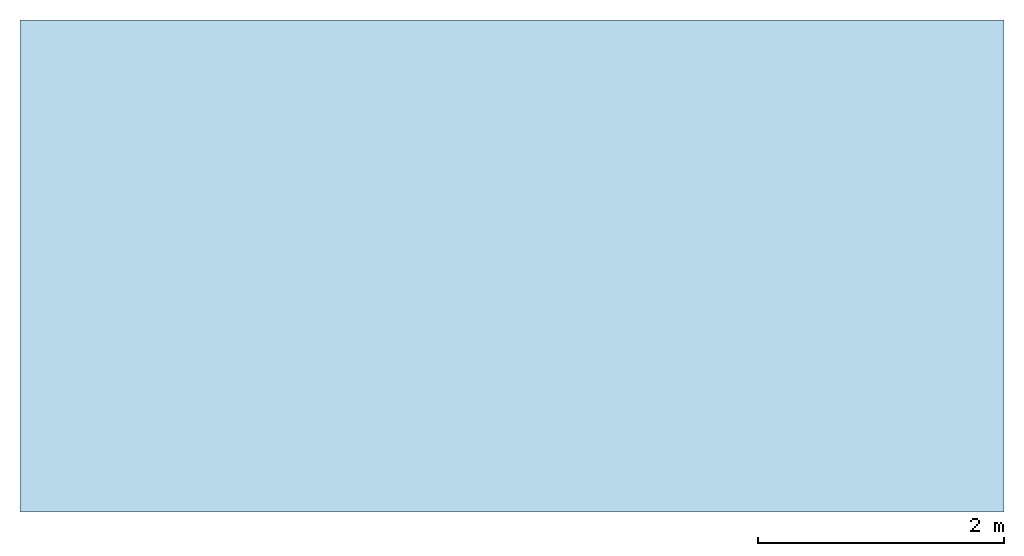
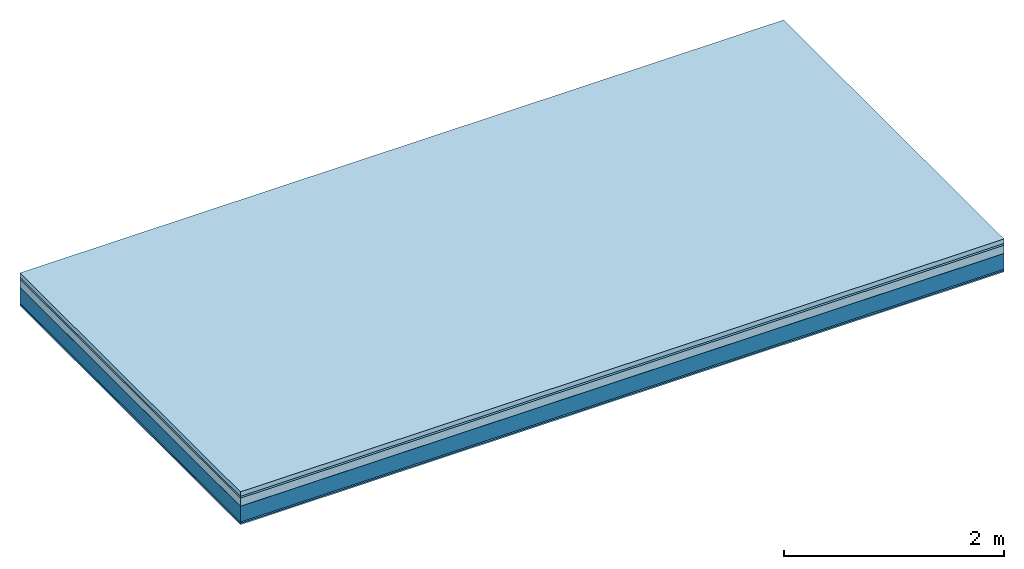
# One storey: 6 plates, 1 member, 1 element without a shape of its own.
"""IFC4 building model written with IfcOpenShell, lengths in metres."""

import ifcopenshell
import ifcopenshell.guid

model = None  # the IFC model being written
_history = None  # IfcOwnerHistory: only IFC2X3 demands one
_inside = {}  # id of a spatial element -> (the spatial element, [elements in it])
_under = {}  # id of a project, library or spatial element -> (it, [spatial elements below it])
_declared = {}  # id of a project -> (the project, [libraries it declares])
_typed = {}  # id of a type object -> (the type object, [elements of that type])
_made_of = {}  # id of a material, layer set ... -> (it, [elements and type objects made of it])


def new_model(schema):
    """Start an empty IFC model of exactly this schema.

    Asked for "IFC4X3", IfcOpenShell would pick the latest addendum, in which some entities
    have other attributes; the version numbers below select the first issue.
    IFC2X3 requires an IfcOwnerHistory on every rooted entity: one is made here for all.
    """
    global model, _history
    if schema == "IFC4X3":
        model = ifcopenshell.file(schema_version=(4, 3, 0, 0))
    else:
        model = ifcopenshell.file(schema=schema)
    _inside.clear()
    _under.clear()
    _declared.clear()
    _typed.clear()
    _made_of.clear()
    _history = None
    if model.schema == "IFC2X3":
        org = make("IfcOrganization", Name="unknown")
        user = make(
            "IfcPersonAndOrganization",
            ThePerson=make("IfcPerson", FamilyName="unknown"),
            TheOrganization=org,
        )
        app = make(
            "IfcApplication",
            ApplicationDeveloper=org,
            Version="unknown",
            ApplicationFullName="unknown",
            ApplicationIdentifier="unknown",
        )
        _history = make(
            "IfcOwnerHistory",
            OwningUser=user,
            OwningApplication=app,
            ChangeAction="ADDED",
            CreationDate=0,
        )
    return model


def make(cls, **values):
    """One entity of the class cls with the attributes given. An attribute that is None is left unset."""
    return model.create_entity(
        cls, **{name: value for name, value in values.items() if value is not None}
    )


def rooted(cls, **values):
    """An entity with a GlobalId (a new one), such as an element, a storey or a relation."""
    return make(cls, GlobalId=ifcopenshell.guid.new(), OwnerHistory=_history, **values)


def si_unit(unit_type, name, prefix=None):
    """IfcSIUnit, for example si_unit("LENGTHUNIT", "METRE", prefix="MILLI")."""
    return make("IfcSIUnit", UnitType=unit_type, Prefix=prefix, Name=name)


def derived_unit(unit_type, elements):
    """IfcDerivedUnit: a product of units, each with its exponent."""
    return make(
        "IfcDerivedUnit",
        Elements=[
            make("IfcDerivedUnitElement", Unit=unit, Exponent=power)
            for unit, power in elements
        ],
        UnitType=unit_type,
    )


def assignment(units):
    """IfcUnitAssignment: the units of a project."""
    return None if units is None else make("IfcUnitAssignment", Units=units)


def point(xyz):
    """IfcCartesianPoint."""
    return None if xyz is None else make("IfcCartesianPoint", Coordinates=xyz)


def direction(xyz):
    """IfcDirection."""
    return None if xyz is None else make("IfcDirection", DirectionRatios=xyz)


def frame(location, z_axis=None, x_axis=None):
    """IfcAxis2Placement3D, a coordinate frame: its origin and axes. An axis left out is left unset."""
    return make(
        "IfcAxis2Placement3D",
        Location=point(location),
        Axis=direction(z_axis),
        RefDirection=direction(x_axis),
    )


def frame_2d(location, x_axis=None):
    """IfcAxis2Placement2D, a coordinate frame in the plane: its origin and x axis."""
    return make(
        "IfcAxis2Placement2D", Location=point(location), RefDirection=direction(x_axis)
    )


def origin():
    """The frame at (0, 0, 0) with its axes left unset."""
    return frame((0.0, 0.0, 0.0))


def origin_with_axes():
    """The frame at (0, 0, 0) with the z axis (0, 0, 1) and the x axis (1, 0, 0) written out."""
    return frame((0.0, 0.0, 0.0), z_axis=(0.0, 0.0, 1.0), x_axis=(1.0, 0.0, 0.0))


def place(relative_to, where):
    """IfcLocalPlacement: puts the frame where relative to a parent placement (None: the world)."""
    return make(
        "IfcLocalPlacement", PlacementRelTo=relative_to, RelativePlacement=where
    )


def context(
    kind, dimensions, precision=None, world=None, true_north=None, identifier=None
):
    """IfcGeometricRepresentationContext, for example the 3D "Model" context."""
    return make(
        "IfcGeometricRepresentationContext",
        ContextIdentifier=identifier,
        ContextType=kind,
        CoordinateSpaceDimension=dimensions,
        Precision=precision,
        WorldCoordinateSystem=world,
        TrueNorth=true_north,
    )


def project(units=None, contexts=None):
    """IfcProject with its units and contexts."""
    return rooted(
        "IfcProject",
        Name="project",
        RepresentationContexts=contexts,
        UnitsInContext=assignment(units),
    )


def spatial(cls, under=None, at=None, **own):
    """A site, building, storey or space (cls), placed at a placement, below another one or the project."""
    s = rooted(cls, ObjectPlacement=at, **own)
    if under is not None:
        _under.setdefault(under.id(), (under, []))[1].append(s)
    return s


def profile(cls, at=None, kind="AREA", **sizes):
    """A parametric profile (cls). Its sizes go by their IFC names, for example OverallWidth=200.0."""
    return make(cls, ProfileType=kind, Position=at, **sizes)


def rectangle(**sizes):
    """IfcRectangleProfileDef."""
    return profile("IfcRectangleProfileDef", **sizes)


def extrude(swept, where, along, depth):
    """IfcExtrudedAreaSolid: the profile swept, set in the frame where, extruded along a direction by depth."""
    return make(
        "IfcExtrudedAreaSolid",
        SweptArea=swept,
        Position=where,
        ExtrudedDirection=direction(along),
        Depth=depth,
    )


def shape(context_of_items, identifier, shape_type, items):
    """IfcShapeRepresentation: the items that make up one representation, for example the "Body"."""
    return make(
        "IfcShapeRepresentation",
        ContextOfItems=context_of_items,
        RepresentationIdentifier=identifier,
        RepresentationType=shape_type,
        Items=items,
    )


def material(Name=None, Category=None):
    """IfcMaterial."""
    return make("IfcMaterial", Name=Name, Category=Category)


def layer(
    of_material, thickness, ventilated=None, Name=None, Category=None, Priority=None
):
    """IfcMaterialLayer: one layer of a wall or slab, of a material (None: an air gap)."""
    return make(
        "IfcMaterialLayer",
        Material=of_material,
        LayerThickness=thickness,
        IsVentilated=ventilated,
        Name=Name,
        Category=Category,
        Priority=Priority,
    )


def layer_set(layers, Name=None):
    """IfcMaterialLayerSet."""
    return make("IfcMaterialLayerSet", MaterialLayers=layers, LayerSetName=Name)


def made_of(thing, what):
    """Note that an element or type object is made of a material, layer set ...; save() writes the relation."""
    if what is not None:
        _made_of.setdefault(what.id(), (what, []))[1].append(thing)
    return thing


def type_object(cls, material=None, **own):
    """A type object (cls), such as IfcWallType, which elements share."""
    return made_of(rooted(cls, **own), material)


def element(
    cls,
    number,
    at=None,
    inside=None,
    cuts=None,
    type_object=None,
    material=None,
    context=None,
    identifier="Body",
    shape_type=None,
    held_by="IfcProductDefinitionShape",
    body=None,
    shapes=None,
    **own,
):
    """One element of the class cls, such as IfcWall. Its Tag is "e" and its number.

    at: its placement. inside: the storey or other place that contains it. cuts: it is an
    opening in that element (IfcRelVoidsElement). A single representation is given by context,
    identifier, shape_type and body (its items); several are given by shapes. held_by: the class
    of the entity that holds the representations. save() writes the other relations.
    """
    e = rooted(cls, Tag="e%d" % number, ObjectPlacement=at, **own)
    if body is not None:
        shapes = [shape(context, identifier, shape_type, body)]
    if shapes is not None:
        e.Representation = make(held_by, Representations=shapes)
    if inside is not None:
        _inside.setdefault(inside.id(), (inside, []))[1].append(e)
    if cuts is not None:
        rooted(
            "IfcRelVoidsElement", RelatingBuildingElement=cuts, RelatedOpeningElement=e
        )
    if type_object is not None:
        _typed.setdefault(type_object.id(), (type_object, []))[1].append(e)
    return made_of(e, material)


def aggregate(whole, parts):
    """IfcRelAggregates: a whole, such as a stair, and the parts it consists of."""
    return rooted("IfcRelAggregates", RelatingObject=whole, RelatedObjects=parts)


def save(model, path):
    """Write the relations noted so far, then the file.

    IfcRelAggregates (storeys below a building ...), IfcRelContainedInSpatialStructure (elements
    in a storey), IfcRelDefinesByType, IfcRelAssociatesMaterial and IfcRelDeclares: one each for
    every whole, place, type object, material and project.
    """
    for whole, parts in _under.values():
        aggregate(whole, parts)
    for where, things in _inside.values():
        rooted(
            "IfcRelContainedInSpatialStructure",
            RelatedElements=things,
            RelatingStructure=where,
        )
    for kind, things in _typed.values():
        rooted("IfcRelDefinesByType", RelatedObjects=things, RelatingType=kind)
    for what, things in _made_of.values():
        rooted("IfcRelAssociatesMaterial", RelatedObjects=things, RelatingMaterial=what)
    for by, libraries in _declared.values():
        rooted("IfcRelDeclares", RelatingContext=by, RelatedDefinitions=libraries)
    model.write(path)


model = new_model("IFC4")

# Units and contexts
plan_context = context("Plan", 3, precision=1e-05, world=origin(), true_north=direction((0.0, 1.0)))
model_context = context("Model", 3, precision=1e-05, world=origin(), true_north=direction((0.0, 1.0)))
ifc_project = project(units=[si_unit("LENGTHUNIT", "METRE"), derived_unit("SOUNDPRESSUREUNIT", [(si_unit("PRESSUREUNIT", "PASCAL", prefix="MICRO"), 0)]), si_unit("ENERGYUNIT", "JOULE", prefix="MEGA"), si_unit("MASSUNIT", "GRAM", prefix="KILO"), derived_unit("THERMALTRANSMITTANCEUNIT", [(si_unit("POWERUNIT", "WATT"), 1), (si_unit("AREAUNIT", "SQUARE_METRE"), -1), (si_unit("THERMODYNAMICTEMPERATUREUNIT", "KELVIN"), -1)]), derived_unit("AREADENSITYUNIT", [(si_unit("MASSUNIT", "GRAM", prefix="KILO"), 1), (si_unit("AREAUNIT", "SQUARE_METRE"), -1)]), derived_unit("USERDEFINED", [(si_unit("ENERGYUNIT", "JOULE", prefix="MEGA"), 1), (si_unit("AREAUNIT", "SQUARE_METRE"), -1)])], contexts=[plan_context, model_context])

# Site, building, storey
site = spatial("IfcSite", under=ifc_project)
building_placement = place(None, origin())
building = spatial("IfcBuilding", under=site, at=building_placement)
storey_placement = place(building_placement, origin())
storey = spatial("IfcBuildingStorey", under=building, at=storey_placement)

# Slab, member, plates
ifc_material_1 = material(Name="Cement screed", Category="04.006")
ifc_layer_1 = layer(ifc_material_1, 0.05, Name="On-material")
ifc_material_2 = material(Name="Impact sound insulation board TPE", Category="10.008")
ifc_layer_2 = layer(ifc_material_2, 0.02, Name="Impact sound insulation")
ifc_material_3 = material(Category="03.011")
ifc_layer_3 = layer(ifc_material_3, 0.09, Name="on Supporting structure")
ifc_material_4 = material(Name="protection", Category="09.007")
ifc_layer_4 = layer(ifc_material_4, 0.0005, Name="Sub-floor")
ifc_material_5 = material(Name="no composite action")
ifc_layer_5 = layer(ifc_material_5, 0.0, Name="Bond")
ifc_layer_6 = layer(None, 0.175, Name="Supporting structure")
ifc_material_6 = material(Category="03.008")
ifc_layer_7 = layer(ifc_material_6, 0.015, Name="Lower layer 1")
ifc_layer_8 = layer(ifc_material_6, 0.015, Name="Lower 2nd layer")
ifc_layer_set = layer_set([ifc_layer_1, ifc_layer_2, ifc_layer_3, ifc_layer_4, ifc_layer_5, ifc_layer_6, ifc_layer_7, ifc_layer_8])
slab_type = type_object("IfcSlabType", Name="A2710", PredefinedType="NOTDEFINED", material=ifc_layer_set)
slab_placement = place(None, frame((0.0, 0.0, 0.0), z_axis=(0.0, 0.0, -1.0), x_axis=(1.0, 0.0, 0.0)))
slab = element("IfcSlab", 1, at=slab_placement, inside=storey, type_object=slab_type, material=ifc_layer_set, Name="Slab #1")
ifc_material_7 = material(Name="OSB")
member_placement = place(slab_placement, origin())
member = element("IfcMember", 2, at=member_placement, material=ifc_material_7, Name="Supporting structure", context=plan_context, shape_type="SweptSolid", body=[
    extrude(rectangle(XDim=1.0, YDim=0.175, at=frame_2d((0.5, 0.0875), x_axis=(1.0, 0.0))), frame((0.0, 4.0, 0.1605), z_axis=(0.0, -1.0, 0.0), x_axis=(1.0, 0.0, 0.0)), (0.0, 0.0, 1.0), 4.0),
    extrude(rectangle(XDim=1.0, YDim=0.175, at=frame_2d((0.5, 0.0875), x_axis=(1.0, 0.0))), frame((1.0, 4.0, 0.1605), z_axis=(0.0, -1.0, 0.0), x_axis=(1.0, 0.0, 0.0)), (0.0, 0.0, 1.0), 4.0),
    extrude(rectangle(XDim=1.0, YDim=0.175, at=frame_2d((0.5, 0.0875), x_axis=(1.0, 0.0))), frame((2.0, 4.0, 0.1605), z_axis=(0.0, -1.0, 0.0), x_axis=(1.0, 0.0, 0.0)), (0.0, 0.0, 1.0), 4.0),
    extrude(rectangle(XDim=1.0, YDim=0.175, at=frame_2d((0.5, 0.0875), x_axis=(1.0, 0.0))), frame((3.0, 4.0, 0.1605), z_axis=(0.0, -1.0, 0.0), x_axis=(1.0, 0.0, 0.0)), (0.0, 0.0, 1.0), 4.0),
    extrude(rectangle(XDim=1.0, YDim=0.175, at=frame_2d((0.5, 0.0875), x_axis=(1.0, 0.0))), frame((4.0, 4.0, 0.1605), z_axis=(0.0, -1.0, 0.0), x_axis=(1.0, 0.0, 0.0)), (0.0, 0.0, 1.0), 4.0),
    extrude(rectangle(XDim=1.0, YDim=0.175, at=frame_2d((0.5, 0.0875), x_axis=(1.0, 0.0))), frame((5.0, 4.0, 0.1605), z_axis=(0.0, -1.0, 0.0), x_axis=(1.0, 0.0, 0.0)), (0.0, 0.0, 1.0), 4.0),
    extrude(rectangle(XDim=1.0, YDim=0.175, at=frame_2d((0.5, 0.0875), x_axis=(1.0, 0.0))), frame((6.0, 4.0, 0.1605), z_axis=(0.0, -1.0, 0.0), x_axis=(1.0, 0.0, 0.0)), (0.0, 0.0, 1.0), 4.0),
    extrude(rectangle(XDim=1.0, YDim=0.175, at=frame_2d((0.5, 0.0875), x_axis=(1.0, 0.0))), frame((7.0, 4.0, 0.1605), z_axis=(0.0, -1.0, 0.0), x_axis=(1.0, 0.0, 0.0)), (0.0, 0.0, 1.0), 4.0),
])
plate_1_placement = place(slab_placement, origin())
plate_1 = element("IfcPlate", 3, at=plate_1_placement, material=ifc_material_1, Name="On-material", context=plan_context, shape_type="SweptSolid", body=[
    extrude(rectangle(XDim=8.0, YDim=4.0, at=frame_2d((4.0, 2.0), x_axis=(1.0, 0.0))), origin_with_axes(), (0.0, 0.0, 1.0), 0.05),
])
plate_2_placement = place(slab_placement, origin())
plate_2 = element("IfcPlate", 4, at=plate_2_placement, material=ifc_material_2, Name="Impact sound insulation", context=plan_context, shape_type="SweptSolid", body=[
    extrude(rectangle(XDim=8.0, YDim=4.0, at=frame_2d((4.0, 2.0), x_axis=(1.0, 0.0))), frame((0.0, 0.0, 0.05), z_axis=(0.0, 0.0, 1.0), x_axis=(1.0, 0.0, 0.0)), (0.0, 0.0, 1.0), 0.02),
])
plate_3_placement = place(slab_placement, origin())
plate_3 = element("IfcPlate", 5, at=plate_3_placement, material=ifc_material_3, Name="on Supporting structure", context=plan_context, shape_type="SweptSolid", body=[
    extrude(rectangle(XDim=8.0, YDim=4.0, at=frame_2d((4.0, 2.0), x_axis=(1.0, 0.0))), frame((0.0, 0.0, 0.07), z_axis=(0.0, 0.0, 1.0), x_axis=(1.0, 0.0, 0.0)), (0.0, 0.0, 1.0), 0.09),
])
plate_4_placement = place(slab_placement, origin())
plate_4 = element("IfcPlate", 6, at=plate_4_placement, material=ifc_material_4, Name="Sub-floor", context=plan_context, shape_type="SweptSolid", body=[
    extrude(rectangle(XDim=8.0, YDim=4.0, at=frame_2d((4.0, 2.0), x_axis=(1.0, 0.0))), frame((0.0, 0.0, 0.16), z_axis=(0.0, 0.0, 1.0), x_axis=(1.0, 0.0, 0.0)), (0.0, 0.0, 1.0), 0.0005),
])
plate_5_placement = place(slab_placement, origin())
plate_5 = element("IfcPlate", 7, at=plate_5_placement, material=ifc_material_6, Name="Lower layer 1", context=plan_context, shape_type="SweptSolid", body=[
    extrude(rectangle(XDim=8.0, YDim=4.0, at=frame_2d((4.0, 2.0), x_axis=(1.0, 0.0))), frame((0.0, 0.0, 0.3355), z_axis=(0.0, 0.0, 1.0), x_axis=(1.0, 0.0, 0.0)), (0.0, 0.0, 1.0), 0.015),
])
plate_6_placement = place(slab_placement, origin())
plate_6 = element("IfcPlate", 8, at=plate_6_placement, material=ifc_material_6, Name="Lower 2nd layer", context=plan_context, shape_type="SweptSolid", body=[
    extrude(rectangle(XDim=8.0, YDim=4.0, at=frame_2d((4.0, 2.0), x_axis=(1.0, 0.0))), frame((0.0, 0.0, 0.3505), z_axis=(0.0, 0.0, 1.0), x_axis=(1.0, 0.0, 0.0)), (0.0, 0.0, 1.0), 0.015),
])
aggregate(slab, [plate_1, plate_2, plate_3, plate_4, member, plate_5, plate_6])

save(model, "model.ifc")
